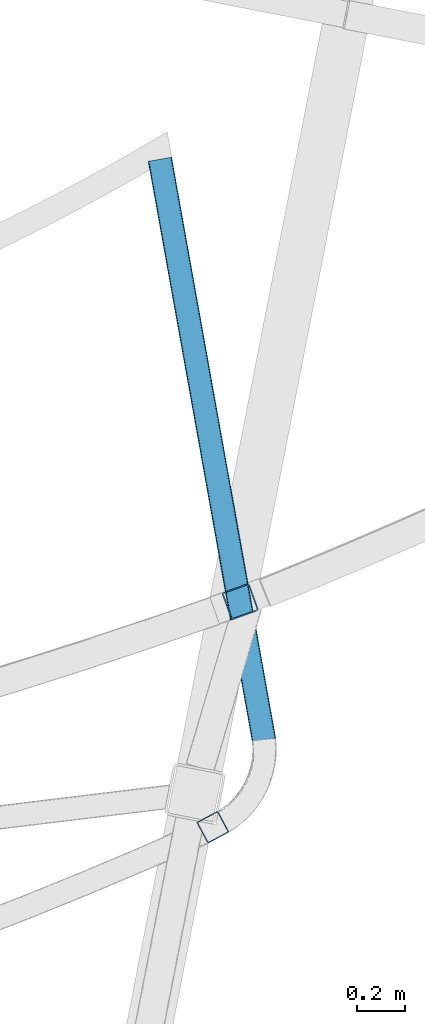
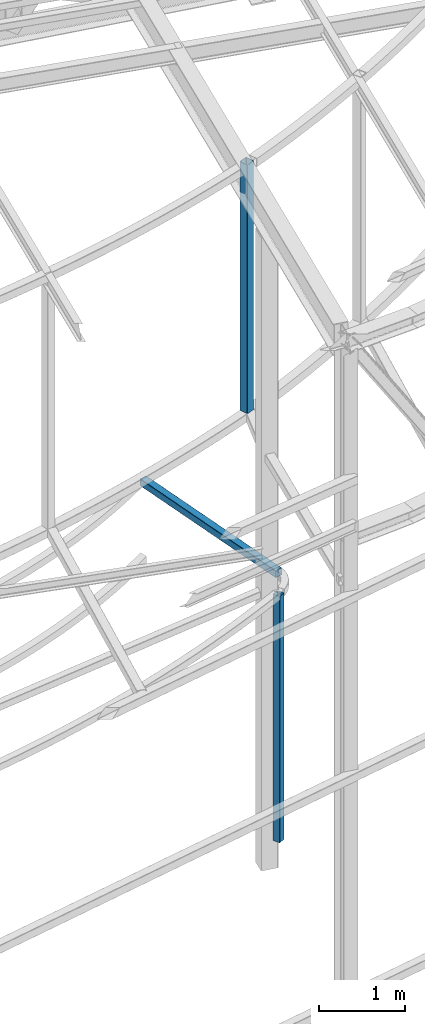
# One storey, part 56 of 215: 3 beams, 3 elements without a shape of their own.
"""IFC2X3 building model written with IfcOpenShell, lengths in millimetres."""

from ifc_helpers import new_model, si_unit, frame, origin_with_axes, origin_2d_with_axis, place, context, subcontext, project, spatial, hollow_rectangle, extrude, material, type_object, element, aggregate, save


model = new_model("IFC2X3")

# Units and contexts
model_context = context("Model", 3, precision=1e-05, world=origin_with_axes())
body_context = subcontext(model_context, "Body", "Model", "MODEL_VIEW")
ifc_project = project(units=[si_unit("LENGTHUNIT", "METRE", prefix="MILLI"), si_unit("AREAUNIT", "SQUARE_METRE"), si_unit("VOLUMEUNIT", "CUBIC_METRE"), si_unit("MASSUNIT", "GRAM", prefix="KILO"), si_unit("TIMEUNIT", "SECOND"), si_unit("PLANEANGLEUNIT", "RADIAN"), si_unit("SOLIDANGLEUNIT", "STERADIAN"), si_unit("THERMODYNAMICTEMPERATUREUNIT", "DEGREE_CELSIUS"), si_unit("LUMINOUSINTENSITYUNIT", "LUMEN")], contexts=[model_context])

# Site, building, storey
site_placement = place(None, origin_with_axes())
site = spatial("IfcSite", under=ifc_project, at=site_placement, CompositionType="ELEMENT")
building_placement = place(site_placement, origin_with_axes())
building = spatial("IfcBuilding", under=site, at=building_placement, Name="Undefined", CompositionType="ELEMENT")
storey_placement = place(building_placement, origin_with_axes())
storey = spatial("IfcBuildingStorey", under=building, at=storey_placement, Name="Undefined", CompositionType="ELEMENT", Elevation=0.0)

# Assembly, beam
assembly_1_placement = place(storey_placement, origin_with_axes())
assembly_1 = element("IfcElementAssembly", 1, at=assembly_1_placement, inside=storey, Name="Steel Assembly", AssemblyPlace="NOTDEFINED", PredefinedType="RIGID_FRAME")
ifc_material = material(Name="STEEL/S275JR")
beam_type_1 = type_object("IfcBeamType", PredefinedType="NOTDEFINED")
beam_1_placement = place(assembly_1_placement, frame((85010.7902270006, 4855.89079924705, 6760.00000147687), z_axis=(-0.984317873295395, -0.17640386705294, 0.0), x_axis=(-0.176403867052938, 0.984317873295395, 0.0)))
beam_1 = element("IfcBeam", 2, at=beam_1_placement, type_object=beam_type_1, material=ifc_material, Name="POUTRE", context=body_context, shape_type="SweptSolid", body=[
    extrude(hollow_rectangle(XDim=100.0, YDim=100.0, WallThickness=4.0, InnerFilletRadius=4.0, OuterFilletRadius=8.0, at=origin_2d_with_axis()), frame((2449.37718287773, 0.0, 0.0), z_axis=(-1.0, 0.0, 0.0), x_axis=(-6.93889390390723e-18, -1.0, -3.46944695195361e-18)), (0.0, 0.0, 1.0), 2449.4),
])
aggregate(assembly_1, [beam_1])

assembly_2_placement = place(storey_placement, origin_with_axes())
assembly_2 = element("IfcElementAssembly", 3, at=assembly_2_placement, inside=storey, Name="Steel Assembly", AssemblyPlace="NOTDEFINED", PredefinedType="RIGID_FRAME")
beam_2_placement = place(assembly_2_placement, frame((84798.2853029338, 4494.93075202367, 6760.00000147429), z_axis=(-0.882021525141128, -0.471209114075394, 0.0), x_axis=(0.0, 0.0, -1.0)))
beam_2 = element("IfcBeam", 4, at=beam_2_placement, type_object=beam_type_1, material=ifc_material, Name="MONTANT", context=body_context, shape_type="SweptSolid", body=[
    extrude(hollow_rectangle(XDim=100.0, YDim=100.0, WallThickness=4.0, InnerFilletRadius=4.0, OuterFilletRadius=8.0, at=origin_2d_with_axis()), frame((3499.99999998675, 0.0, 0.0), z_axis=(-1.0, 0.0, 0.0), x_axis=(-6.93889390390723e-18, -1.0, -3.46944695195361e-18)), (0.0, 0.0, 1.0), 3500.0),
])
aggregate(assembly_2, [beam_2])

assembly_3_placement = place(storey_placement, origin_with_axes())
assembly_3 = element("IfcElementAssembly", 5, at=assembly_3_placement, inside=storey, Name="Steel Assembly", AssemblyPlace="NOTDEFINED", PredefinedType="RIGID_FRAME")
beam_type_2 = type_object("IfcBeamType", PredefinedType="NOTDEFINED")
beam_3_placement = place(assembly_3_placement, frame((84911.8590566446, 5431.14897593914, 12301.8735079322), z_axis=(0.338061846996747, -0.941123895990931, 0.0), x_axis=(0.0, 0.0, -1.0)))
beam_3 = element("IfcBeam", 6, at=beam_3_placement, type_object=beam_type_2, material=ifc_material, Name="LISSE", context=body_context, shape_type="SweptSolid", body=[
    extrude(hollow_rectangle(XDim=120.0, YDim=120.0, WallThickness=5.0, InnerFilletRadius=5.0, OuterFilletRadius=10.0, at=origin_2d_with_axis()), frame((3535.87271378682, 0.0, -7.31201339324928e-22), z_axis=(-1.0, 0.0, 0.0), x_axis=(-6.93889390390723e-18, -1.0, -3.46944695195361e-18)), (0.0, 0.0, 1.0), 3535.9),
])
aggregate(assembly_3, [beam_3])

save(model, "model.ifc")
